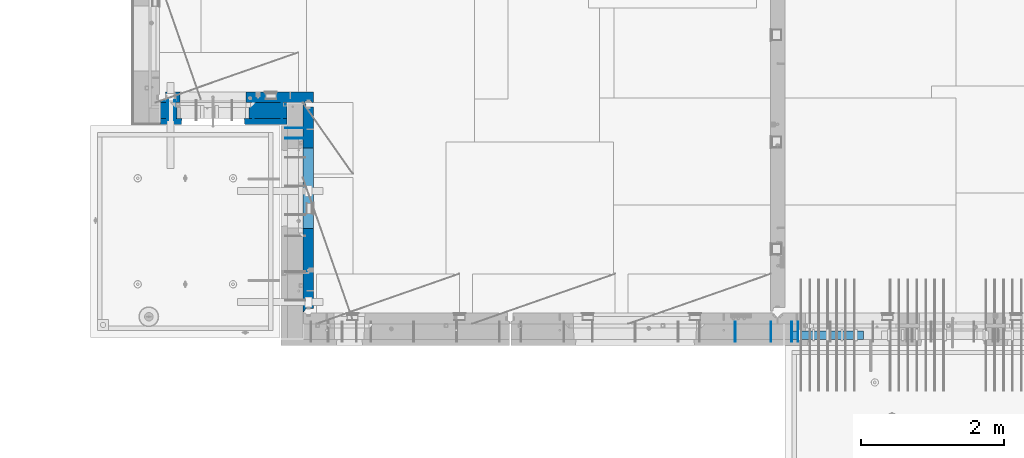
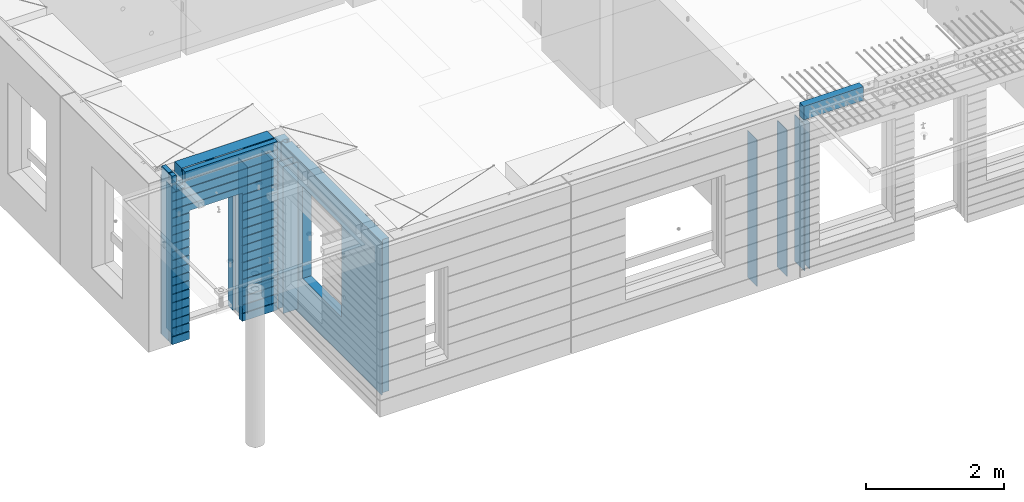
# One storey, part 220 of 341: 15 walls, 6 elements without a shape of their own.
"""IFC2X3 building model written with IfcOpenShell, lengths in millimetres."""

from ifc_helpers import new_model, si_unit, frame, origin_with_axes, place, context, subcontext, project, spatial, faceted_brep, material, type_object, element, aggregate, save


model = new_model("IFC2X3")

# Units and contexts
model_context = context("Model", 3, precision=1e-05, world=origin_with_axes())
body_context = subcontext(model_context, "Body", "Model", "MODEL_VIEW")
ifc_project = project(units=[si_unit("LENGTHUNIT", "METRE", prefix="MILLI"), si_unit("AREAUNIT", "SQUARE_METRE"), si_unit("VOLUMEUNIT", "CUBIC_METRE"), si_unit("MASSUNIT", "GRAM", prefix="KILO"), si_unit("TIMEUNIT", "SECOND"), si_unit("PLANEANGLEUNIT", "RADIAN"), si_unit("SOLIDANGLEUNIT", "STERADIAN"), si_unit("THERMODYNAMICTEMPERATUREUNIT", "DEGREE_CELSIUS"), si_unit("LUMINOUSINTENSITYUNIT", "LUMEN")], contexts=[model_context])

# Site, building, storey
site_placement = place(None, origin_with_axes())
site = spatial("IfcSite", under=ifc_project, at=site_placement, CompositionType="ELEMENT")
building_placement = place(site_placement, origin_with_axes())
building = spatial("IfcBuilding", under=site, at=building_placement, CompositionType="ELEMENT")
storey_placement = place(building_placement, origin_with_axes())
storey = spatial("IfcBuildingStorey", under=building, at=storey_placement, Name="5", CompositionType="ELEMENT", Elevation=0.0)

# Assembly, wall
assembly_1_placement = place(storey_placement, origin_with_axes())
assembly_1 = element("IfcElementAssembly", 1, at=assembly_1_placement, inside=storey, AssemblyPlace="NOTDEFINED", PredefinedType="REINFORCEMENT_UNIT")
ifc_material_1 = material(Name="Undefined")
wall_type_1 = type_object("IfcWallType", PredefinedType="NOTDEFINED")
wall_1_placement = place(assembly_1_placement, frame((16855.0, 7880.0, 95115.0), z_axis=(0.0, 0.0, 1.0), x_axis=(0.0, -1.0, 0.0)))
wall_1 = element("IfcWall", 2, at=wall_1_placement, type_object=wall_type_1, material=ifc_material_1, Name="(PD)", context=body_context, shape_type="Brep", body=[
    faceted_brep([(0.0, 5.0, -1300.0), (0.0, 5.0, 1300.0), (280.0, 5.0, 1300.0), (280.0, 5.0, -1300.0), (0.0, -5.0, 1300.0), (280.0, -5.0, 1300.0), (0.0, -5.0, -1300.0), (280.0, -5.0, -1300.0)], [[[0, 1, 2, 3]], [[1, 4, 5, 2]], [[4, 6, 7, 5]], [[6, 0, 3, 7]], [[5, 7, 3, 2]], [[6, 4, 1, 0]]]),
])

# Assembly, walls
assembly_2_placement = place(storey_placement, origin_with_axes())
assembly_2 = element("IfcElementAssembly", 3, at=assembly_2_placement, inside=storey, AssemblyPlace="NOTDEFINED", PredefinedType="REINFORCEMENT_UNIT")
wall_2_placement = place(assembly_2_placement, frame((16565.0, 7880.0, 95115.0), z_axis=(0.0, 0.0, 1.0), x_axis=(0.0, -1.0, 0.0)))
wall_2 = element("IfcWall", 4, at=wall_2_placement, type_object=wall_type_1, material=ifc_material_1, Name="(PD)", context=body_context, shape_type="Brep", body=[
    faceted_brep([(0.0, 5.0, -1300.0), (0.0, 5.0, 1300.0), (280.0, 5.0, 1300.0), (280.0, 5.0, -1300.0), (0.0, -5.0, 1300.0), (280.0, -5.0, 1300.0), (0.0, -5.0, -1300.0), (280.0, -5.0, -1300.0)], [[[0, 1, 2, 3]], [[1, 4, 5, 2]], [[4, 6, 7, 5]], [[6, 0, 3, 7]], [[5, 7, 3, 2]], [[6, 4, 1, 0]]]),
])
wall_3_placement = place(assembly_2_placement, frame((16065.0, 7880.0, 95115.0), z_axis=(0.0, 0.0, 1.0), x_axis=(0.0, -1.0, 0.0)))
wall_3 = element("IfcWall", 5, at=wall_3_placement, type_object=wall_type_1, material=ifc_material_1, Name="(PD)", context=body_context, shape_type="Brep", body=[
    faceted_brep([(0.0, 5.0, -1300.0), (0.0, 5.0, 1300.0), (280.0, 5.0, 1300.0), (280.0, 5.0, -1300.0), (0.0, -5.0, 1300.0), (280.0, -5.0, 1300.0), (0.0, -5.0, -1300.0), (280.0, -5.0, -1300.0)], [[[0, 1, 2, 3]], [[1, 4, 5, 2]], [[4, 6, 7, 5]], [[6, 0, 3, 7]], [[5, 7, 3, 2]], [[6, 4, 1, 0]]]),
])
aggregate(assembly_2, [wall_2, wall_3])

# Assembly, wall
assembly_3_placement = place(storey_placement, origin_with_axes())
assembly_3 = element("IfcElementAssembly", 6, at=assembly_3_placement, inside=storey, AssemblyPlace="NOTDEFINED", PredefinedType="REINFORCEMENT_UNIT")
wall_4_placement = place(assembly_3_placement, frame((8215.0, 10980.0, 95115.0), z_axis=(0.0, 0.0, 1.0), x_axis=(0.0, -1.0, 0.0)))
wall_4 = element("IfcWall", 7, at=wall_4_placement, type_object=wall_type_1, material=ifc_material_1, Name="(PD)", context=body_context, shape_type="Brep", body=[
    faceted_brep([(0.0, 5.0, -1300.0), (0.0, 5.0, 1300.0), (280.0, 5.0, 1300.0), (280.0, 5.0, -1300.0), (0.0, -5.0, 1300.0), (280.0, -5.0, 1300.0), (0.0, -5.0, -1300.0), (280.0, -5.0, -1300.0)], [[[0, 1, 2, 3]], [[1, 4, 5, 2]], [[4, 6, 7, 5]], [[6, 0, 3, 7]], [[5, 7, 3, 2]], [[6, 4, 1, 0]]]),
])

# Assembly, walls
assembly_4_placement = place(storey_placement, origin_with_axes())
assembly_4 = element("IfcElementAssembly", 8, at=assembly_4_placement, inside=storey, AssemblyPlace="NOTDEFINED", PredefinedType="REINFORCEMENT_UNIT")
wall_5_placement = place(assembly_4_placement, frame((10040.0, 10595.0, 95115.0), z_axis=(0.0, 0.0, 1.0), x_axis=(-1.0, 3.00000001838171e-08, 0.0)))
wall_5 = element("IfcWall", 9, at=wall_5_placement, type_object=wall_type_1, material=ifc_material_1, Name="(PD)", context=body_context, shape_type="Brep", body=[
    faceted_brep([(0.0, 5.0, -1300.0), (0.0, 5.0, 1300.0), (280.0, 5.0, 1300.0), (280.0, 5.0, -1300.0), (0.0, -5.0, 1300.0), (280.0, -5.0, 1300.0), (0.0, -5.0, -1300.0), (280.0, -5.0, -1300.0)], [[[0, 1, 2, 3]], [[1, 4, 5, 2]], [[4, 6, 7, 5]], [[6, 0, 3, 7]], [[5, 7, 3, 2]], [[6, 4, 1, 0]]]),
])
wall_6_placement = place(assembly_4_placement, frame((10040.0, 10450.0, 95115.0), z_axis=(0.0, 0.0, 1.0), x_axis=(-1.0, 3.00000001838171e-08, 0.0)))
wall_6 = element("IfcWall", 10, at=wall_6_placement, type_object=wall_type_1, material=ifc_material_1, Name="(PD)", context=body_context, shape_type="Brep", body=[
    faceted_brep([(0.0, 5.0, -1300.0), (0.0, 5.0, 1300.0), (280.0, 5.0, 1300.0), (280.0, 5.0, -1300.0), (0.0, -5.0, 1300.0), (280.0, -5.0, 1300.0), (0.0, -5.0, -1300.0), (280.0, -5.0, -1300.0)], [[[0, 1, 2, 3]], [[1, 4, 5, 2]], [[4, 6, 7, 5]], [[6, 0, 3, 7]], [[5, 7, 3, 2]], [[6, 4, 1, 0]]]),
])

# Wall
wall_7_placement = place(assembly_1_placement, frame((16945.0, 7880.0, 95115.0), z_axis=(0.0, 0.0, 1.0), x_axis=(0.0, -1.0, 0.0)))
wall_7 = element("IfcWall", 11, at=wall_7_placement, type_object=wall_type_1, material=ifc_material_1, Name="(PD)", context=body_context, shape_type="Brep", body=[
    faceted_brep([(0.0, 5.0, -1300.0), (0.0, 5.0, 1300.0), (280.0, 5.0, 1300.0), (280.0, 5.0, -1300.0), (0.0, -5.0, 1300.0), (280.0, -5.0, 1300.0), (0.0, -5.0, -1300.0), (280.0, -5.0, -1300.0)], [[[0, 1, 2, 3]], [[1, 4, 5, 2]], [[4, 6, 7, 5]], [[6, 0, 3, 7]], [[5, 7, 3, 2]], [[6, 4, 1, 0]]]),
])

aggregate(assembly_1, [wall_1, wall_7])

wall_8_placement = place(assembly_3_placement, frame((8115.0, 10980.0, 95115.0), z_axis=(0.0, 0.0, 1.0), x_axis=(0.0, -1.0, 0.0)))
wall_8 = element("IfcWall", 12, at=wall_8_placement, type_object=wall_type_1, material=ifc_material_1, Name="(PD)", context=body_context, shape_type="Brep", body=[
    faceted_brep([(0.0, 5.0, -1300.0), (0.0, 5.0, 1300.0), (280.0, 5.0, 1300.0), (280.0, 5.0, -1300.0), (0.0, -5.0, 1300.0), (280.0, -5.0, 1300.0), (0.0, -5.0, -1300.0), (280.0, -5.0, -1300.0)], [[[0, 1, 2, 3]], [[1, 4, 5, 2]], [[4, 6, 7, 5]], [[6, 0, 3, 7]], [[5, 7, 3, 2]], [[6, 4, 1, 0]]]),
])

wall_9_placement = place(assembly_3_placement, frame((9315.0, 10980.0, 95115.0), z_axis=(0.0, 0.0, 1.0), x_axis=(0.0, -1.0, 0.0)))
wall_9 = element("IfcWall", 13, at=wall_9_placement, type_object=wall_type_1, material=ifc_material_1, Name="(PD)", context=body_context, shape_type="Brep", body=[
    faceted_brep([(0.0, 5.0, -1300.0), (0.0, 5.0, 1300.0), (280.0, 5.0, 1300.0), (280.0, 5.0, -1300.0), (0.0, -5.0, 1300.0), (280.0, -5.0, 1300.0), (0.0, -5.0, -1300.0), (280.0, -5.0, -1300.0)], [[[0, 1, 2, 3]], [[1, 4, 5, 2]], [[4, 6, 7, 5]], [[6, 0, 3, 7]], [[5, 7, 3, 2]], [[6, 4, 1, 0]]]),
])

wall_10_placement = place(assembly_3_placement, frame((9715.0, 10980.0, 95115.0), z_axis=(0.0, 0.0, 1.0), x_axis=(0.0, -1.0, 0.0)))
wall_10 = element("IfcWall", 14, at=wall_10_placement, type_object=wall_type_1, material=ifc_material_1, Name="(PD)", context=body_context, shape_type="Brep", body=[
    faceted_brep([(0.0, 5.0, -1300.0), (0.0, 5.0, 1300.0), (280.0, 5.0, 1300.0), (280.0, 5.0, -1300.0), (0.0, -5.0, 1300.0), (280.0, -5.0, 1300.0), (0.0, -5.0, -1300.0), (280.0, -5.0, -1300.0)], [[[0, 1, 2, 3]], [[1, 4, 5, 2]], [[4, 6, 7, 5]], [[6, 0, 3, 7]], [[5, 7, 3, 2]], [[6, 4, 1, 0]]]),
])

# Assemblies, wall
assembly_5_placement = place(storey_placement, origin_with_axes())
assembly_5 = element("IfcElementAssembly", 15, at=assembly_5_placement, inside=storey, AssemblyPlace="NOTDEFINED", PredefinedType="REINFORCEMENT_UNIT")
assembly_6_placement = place(assembly_5_placement, origin_with_axes())
assembly_6 = element("IfcElementAssembly", 16, at=assembly_6_placement, Name="Steel Assembly", AssemblyPlace="NOTDEFINED", PredefinedType="NOTDEFINED")
aggregate(assembly_5, [assembly_6])
ifc_material_2 = material()
wall_type_2 = type_object("IfcWallType", PredefinedType="NOTDEFINED")
wall_11_placement = place(assembly_6_placement, frame((16859.9998568133, 7690.00021946163, 96590.0), z_axis=(0.0, 0.0, 1.0), x_axis=(1.0, 0.0, 0.0)))
wall_11 = element("IfcWall", 17, at=wall_11_placement, type_object=wall_type_2, material=ifc_material_2, context=body_context, shape_type="Brep", body=[
    faceted_brep([(0.0, 60.0, -120.0), (0.0, 60.0, 120.0), (1000.0, 60.0, 120.0), (1000.0, 60.0, -120.0), (0.0, -60.0, 120.0), (1000.0, -60.0, 120.0), (0.0, -60.0, -120.0), (1000.0, -60.0, -120.0)], [[[0, 1, 2, 3]], [[1, 4, 5, 2]], [[4, 6, 7, 5]], [[6, 0, 3, 7]], [[5, 7, 3, 2]], [[6, 4, 1, 0]]]),
])
aggregate(assembly_6, [wall_11])

# Wall
ifc_material_3 = material(Name="COS5gt")
wall_type_3 = type_object("IfcWallType", PredefinedType="NOTDEFINED")
wall_12_placement = place(assembly_3_placement, frame((9784.0, 10840.0, 95247.5), z_axis=(0.0, 0.0, 1.0), x_axis=(-1.0, 3.00000001838171e-08, 0.0)))
wall_12 = element("IfcWall", 18, at=wall_12_placement, type_object=wall_type_3, material=ifc_material_3, context=body_context, shape_type="Brep", body=[
    faceted_brep([(1699.0, -110.0, 1492.5), (1699.0, 90.0, 1492.5), (1699.0, 90.0, 1442.5), (1699.0, 110.0, 1442.5), (1699.0, 110.0, 1222.5), (1699.0, -110.0, 1222.5), (1549.0, 110.0, 1222.5), (1549.0, -110.0, 1222.5), (1549.0, -110.0, 1492.5), (1549.0, 110.0, 1442.5), (1549.0, 90.0, 1442.5), (1549.0, 90.0, 1492.5), (0.0, -110.0, -1492.5), (0.0, 90.0, -1492.5), (529.001442432404, 90.0, -1492.5), (529.001442432404, -110.0, -1492.5), (0.0, 90.0, -1442.5), (0.0, 110.0, -1442.5), (529.001442432404, 110.0, -1442.5), (529.001442432404, 90.0, -1442.5), (1769.0, 90.0, -1442.5), (1769.0, 90.0, -1492.5), (1539.0014424324, 90.0, -1492.5), (1539.0014424324, 90.0, -1442.5), (1769.0, 110.0, -1442.5), (1539.0014424324, 110.0, -1442.5), (1769.0, 110.0, 1442.5), (1769.0, 90.0, 1442.5), (1769.0, 90.0, 1492.5), (1769.0, -110.0, 1492.5), (1769.0, -110.0, -1492.5), (1539.0014424324, -110.0, -1492.5), (1539.0014424324, -110.0, 847.5), (1539.0014424324, 110.0, 847.5), (529.001442432404, -110.0, 847.5), (529.001442432404, 110.0, 847.5), (0.0, -110.0, 1492.5), (0.0, 90.0, 1492.5), (0.0, 90.0, 1442.5), (0.0, 110.0, 1442.5)], [[[0, 1, 2, 3, 4, 5]], [[5, 4, 6, 7]], [[8, 7, 6, 9, 10, 11]], [[12, 13, 14, 15]], [[16, 17, 18, 19]], [[20, 21, 22, 23]], [[24, 20, 23, 25]], [[26, 27, 28, 29, 30, 21, 20, 24]], [[21, 30, 31, 22]], [[32, 33, 25, 23, 22, 31]], [[34, 35, 33, 32]], [[15, 14, 19, 18, 35, 34]], [[13, 16, 19, 14]], [[13, 12, 36, 37, 38, 39, 17, 16]], [[37, 36, 8, 11]], [[38, 37, 11, 10]], [[39, 38, 10, 9]], [[4, 3, 26, 24, 25, 33, 35, 18, 17, 39, 9, 6]], [[27, 26, 3, 2]], [[28, 27, 2, 1]], [[29, 28, 1, 0]], [[36, 12, 15, 34, 32, 31, 30, 29, 0, 5, 7, 8]]]),
])

ifc_material_4 = material(Name="CONCRETE/C30/37")
wall_type_4 = type_object("IfcWallType", PredefinedType="NOTDEFINED")
wall_13_placement = place(assembly_3_placement, frame((9784.0, 10687.5, 95247.5), z_axis=(0.0, 0.0, 1.0), x_axis=(-1.0, 3.00000001838171e-08, 0.0)))
wall_13 = element("IfcWall", 19, at=wall_13_placement, type_object=wall_type_4, material=ifc_material_4, context=body_context, shape_type="Brep", body=[
    faceted_brep([(1699.0, -42.5, 1492.5), (1699.0, 42.5, 1492.5), (1699.0, 42.5, 1356.99999988925), (1699.0, 32.4999991126988, 1355.00000040044), (1699.0, 32.4999992506928, 1344.99999999921), (1699.0, 42.5, 1342.99999994476), (1699.0, 42.5, 1222.5), (1699.0, -42.5, 1222.5), (1549.0, 42.5, 1222.5), (1549.0, -42.5, 1222.5), (1549.0, -42.5, 1492.5), (1549.0, 42.5, 1342.99999994476), (1549.0, 32.4999992506928, 1344.99999999921), (1549.0, 32.4999991126988, 1355.00000040044), (1549.0, 42.5, 1356.99999988925), (1549.0, 42.5, 1492.5), (1478.99938360887, 42.5, 606.999999889245), (1769.0, 42.5, 606.999999889245), (1769.0, 32.4999991126988, 605.00000040044), (1477.8227168378, 32.4999991126988, 605.00000040044), (1769.0, 32.4999992506928, 594.999999999214), (1477.82271685404, 32.4999992506928, 594.999999999214), (1769.0, 42.5, 592.999999944761), (1478.99938360887, 42.5, 592.999999944761), (1769.0, 42.5, 456.999999889245), (1478.99938360887, 42.5, 456.999999889245), (1769.0, 32.4999991126988, 455.00000040044), (1477.8227168378, 32.4999991126988, 455.00000040044), (1769.0, 32.4999992506928, 444.999999999214), (1477.82271685404, 32.4999992506928, 444.999999999214), (1769.0, 42.5, 442.999999944761), (1478.99938360887, 42.5, 442.999999944761), (1769.0, 42.5, 306.999999889245), (1478.99938360887, 42.5, 306.999999889245), (1769.0, 32.4999991126988, 305.00000040044), (1477.8227168378, 32.4999991126988, 305.00000040044), (1769.0, 32.4999992506928, 294.999999999214), (1477.82271685404, 32.4999992506928, 294.999999999214), (1769.0, 42.5, 292.999999944761), (1478.99938360887, 42.5, 292.999999944761), (1769.0, 42.5, 156.999999889245), (1478.99938360887, 42.5, 156.999999889245), (1769.0, 32.4999991126988, 155.00000040044), (1477.8227168378, 32.4999991126988, 155.00000040044), (1769.0, 32.4999992506928, 144.999999999214), (1477.82271685404, 32.4999992506928, 144.999999999214), (1769.0, 42.5, 142.999999944761), (1478.99938360887, 42.5, 142.999999944761), (1769.0, 42.5, 6.99999988924537), (1478.99938360887, 42.5, 6.99999988924537), (1769.0, 32.4999991126988, 5.0000004004396), (1477.8227168378, 32.4999991126988, 5.0000004004396), (1769.0, 32.4999992506928, -5.0000000007858), (1477.82271685404, 32.4999992506928, -5.0000000007858), (1769.0, 42.5, -7.00000005523907), (1478.99938360887, 42.5, -7.00000005523907), (1769.0, 42.5, -143.000000110755), (1478.99938360887, 42.5, -143.000000110755), (1769.0, 32.4999991126988, -144.99999959956), (1477.8227168378, 32.4999991126988, -144.99999959956), (1769.0, 32.4999992506928, -155.000000000786), (1477.82271685404, 32.4999992506928, -155.000000000786), (1769.0, 42.5, -157.000000055239), (1478.99938360887, 42.5, -157.000000055239), (1769.0, 42.5, -293.000000110755), (1478.99938360887, 42.5, -293.000000110755), (1769.0, 32.4999991126988, -294.99999959956), (1477.8227168378, 32.4999991126988, -294.99999959956), (1769.0, 32.4999992506928, -305.000000000786), (1477.82271685404, 32.4999992506928, -305.000000000786), (1769.0, 42.5, -307.000000055239), (1478.99938360887, 42.5, -307.000000055239), (1769.0, 42.5, -443.000000110755), (1478.99938360887, 42.5, -443.000000110755), (1769.0, 32.4999991126988, -444.99999959956), (1477.8227168378, 32.4999991126988, -444.99999959956), (1769.0, 32.4999992506928, -455.000000000786), (1477.82271685404, 32.4999992506928, -455.000000000786), (1769.0, 42.5, -457.000000055239), (1478.99938360887, 42.5, -457.000000055239), (1769.0, 42.5, -593.000000110755), (1478.99938360887, 42.5, -593.000000110755), (1769.0, 32.4999991126988, -594.99999959956), (1477.8227168378, 32.4999991126988, -594.99999959956), (1769.0, 32.4999992506928, -605.000000000786), (1477.82271685404, 32.4999992506928, -605.000000000786), (1769.0, 42.5, -607.000000055239), (1478.99938360887, 42.5, -607.000000055239), (1769.0, 42.5, -743.000000110755), (1478.99938360887, 42.5, -743.000000110755), (1769.0, 32.4999991126988, -744.99999959956), (1477.8227168378, 32.4999991126988, -744.99999959956), (1769.0, 32.4999992506928, -755.000000000786), (1477.82271685404, 32.4999992506928, -755.000000000786), (1769.0, 42.5, -757.000000055239), (1478.99938360887, 42.5, -757.000000055239), (1769.0, 42.5, -893.000000110755), (1478.99938360887, 42.5, -893.000000110755), (1769.0, 32.4999991126988, -894.99999959956), (1477.8227168378, 32.4999991126988, -894.99999959956), (1769.0, 32.4999992506928, -905.000000000786), (1477.82271685404, 32.4999992506928, -905.000000000786), (1769.0, 42.5, -907.000000055239), (1478.99938360887, 42.5, -907.000000055239), (1769.0, 42.5, -1043.00000011075), (1478.99938360887, 42.5, -1043.00000011075), (1769.0, 32.4999991126988, -1044.99999959956), (1477.8227168378, 32.4999991126988, -1044.99999959956), (1769.0, 32.4999992506928, -1055.00000000079), (1477.82271685404, 32.4999992506928, -1055.00000000079), (1769.0, 42.5, -1057.00000005524), (1478.99938360887, 42.5, -1057.00000005524), (1769.0, 42.5, -1193.00000011075), (1478.99938360887, 42.5, -1193.00000011075), (1769.0, 32.4999991126988, -1194.99999959956), (1477.8227168378, 32.4999991126988, -1194.99999959956), (1769.0, 32.4999992506928, -1205.00000000079), (1477.82271685404, 32.4999992506928, -1205.00000000079), (1769.0, 42.5, -1207.00000005524), (1478.99938360887, 42.5, -1207.00000005524), (1769.0, 42.5, -1343.00000011075), (1478.99938360887, 42.5, -1343.00000011075), (1769.0, 32.4999991126988, -1344.99999959956), (1477.8227168378, 32.4999991126988, -1344.99999959956), (1769.0, 32.4999992506928, -1355.00000000079), (1477.82271685404, 32.4999992506928, -1355.00000000079), (1769.0, 42.5, -1357.00000005524), (1478.99938360887, 42.5, -1357.00000005524), (1769.0, 42.5, -1492.5), (1478.99938360887, 42.5, -1492.5), (1769.0, -42.5, -1492.5), (1468.99771694221, -42.5, -1492.5), (599.001442432404, 42.5, 782.5), (1469.0014424324, 42.5, 782.5), (1478.99938360887, 42.5, 782.5), (1468.99771694221, -42.5, 787.502857142856), (599.001050275541, -42.5, 787.502857142856), (588.999383608874, 42.5, 782.5), (1478.99938360887, 42.5, 742.999999944761), (1468.99771694221, -42.5, 782.5), (1478.99938360887, 42.5, 756.999999889245), (1477.82271683781, 32.4999991126988, 755.00000040044), (1477.82271685404, 32.4999992506928, 744.999999999214), (1769.0, 42.5, 742.999999944761), (1769.0, 32.4999992506928, 744.999999999214), (1769.0, 32.4999991126988, 755.00000040044), (1769.0, 42.5, 756.999999889245), (0.0, 32.4999991127006, 905.00000040044), (1769.0, 32.4999991126988, 905.00000040044), (1769.0, 32.4999992506928, 894.999999999214), (0.0, 32.4999992507037, 894.999999999258), (0.0, 42.5, 906.999999889245), (1769.0, 42.5, 906.999999889245), (0.0, 42.5, 1042.99999994476), (1769.0, 42.5, 1042.99999994476), (0.0, 32.4999992507037, 1044.99999999926), (1769.0, 32.4999992506928, 1044.99999999921), (0.0, 32.4999991127006, 1055.00000040044), (1769.0, 32.4999991126988, 1055.00000040044), (0.0, 42.5, 1056.99999988925), (1769.0, 42.5, 1056.99999988925), (0.0, 42.5, 1192.99999994476), (1769.0, 42.5, 1192.99999994476), (0.0, 32.4999992507037, 1194.99999999926), (1769.0, 32.4999992506928, 1194.99999999921), (0.0, 32.4999991127006, 1205.00000040044), (1769.0, 32.4999991126988, 1205.00000040044), (0.0, 42.5, 1206.99999988925), (1769.0, 42.5, 1206.99999988925), (1769.0, 42.5, 1492.5), (1769.0, -42.5, 1492.5), (1769.0, 42.5, 892.999999944761), (1769.0, 42.5, 1342.99999994476), (1769.0, 32.4999992506928, 1344.99999999921), (1769.0, 32.4999991126988, 1355.00000040044), (1769.0, 42.5, 1356.99999988925), (0.0, 42.5, 892.999999944761), (588.999383608874, 42.5, 756.999999889245), (0.0, 42.5, 756.999999889245), (588.999383608874, 42.5, -1492.5), (0.0, 42.5, -1492.5), (0.0, 42.5, -1357.00000005524), (588.999383608874, 42.5, -1357.00000005524), (0.0, 32.4999992507037, -1355.00000000074), (590.176050363707, 32.4999992506928, -1355.00000000079), (0.0, 32.4999991127006, -1344.99999959956), (590.176050379945, 32.4999991126988, -1344.99999959956), (0.0, 42.5, -1343.00000011075), (588.999383608874, 42.5, -1343.00000011075), (0.0, 42.5, -1207.00000005524), (588.999383608874, 42.5, -1207.00000005524), (0.0, 32.4999992507037, -1205.00000000074), (590.176050363709, 32.4999992506928, -1205.00000000079), (0.0, 32.4999991127006, -1194.99999959956), (590.176050379947, 32.4999991126988, -1194.99999959956), (0.0, 42.5, -1193.00000011075), (588.999383608874, 42.5, -1193.00000011075), (0.0, 42.5, -1057.00000005524), (588.999383608874, 42.5, -1057.00000005524), (0.0, 32.4999992507037, -1055.00000000074), (590.176050363711, 32.4999992506928, -1055.00000000079), (0.0, 32.4999991127006, -1044.99999959956), (590.176050379947, 32.4999991126988, -1044.99999959956), (0.0, 42.5, -1043.00000011075), (588.999383608874, 42.5, -1043.00000011075), (0.0, 42.5, -907.000000055239), (588.999383608874, 42.5, -907.000000055239), (0.0, 32.4999992507037, -905.000000000742), (590.176050363711, 32.4999992506928, -905.000000000786), (0.0, 32.4999991127006, -894.99999959956), (590.176050379947, 32.4999991126988, -894.99999959956), (0.0, 42.5, -893.000000110755), (588.999383608874, 42.5, -893.000000110755), (0.0, 42.5, -757.000000055239), (588.999383608874, 42.5, -757.000000055239), (0.0, 32.4999992507037, -755.000000000742), (590.176050363711, 32.4999992506928, -755.000000000786), (0.0, 32.4999991127006, -744.99999959956), (590.176050379947, 32.4999991126988, -744.99999959956), (0.0, 42.5, -743.000000110755), (588.999383608874, 42.5, -743.000000110755), (0.0, 42.5, -607.000000055239), (588.999383608874, 42.5, -607.000000055239), (3.63797880709171e-12, 32.4999992507037, -605.000000000742), (590.176050363709, 32.4999992506928, -605.000000000786), (3.63797880709171e-12, 32.4999991127006, -594.99999959956), (590.176050379947, 32.4999991126988, -594.99999959956), (0.0, 42.5, -593.000000110755), (588.999383608874, 42.5, -593.000000110755), (0.0, 42.5, -457.000000055239), (588.999383608874, 42.5, -457.000000055239), (0.0, 32.4999992507037, -455.000000000742), (590.176050363711, 32.4999992506928, -455.000000000786), (0.0, 32.4999991127006, -444.99999959956), (590.176050379947, 32.4999991126988, -444.99999959956), (0.0, 42.5, -443.000000110755), (588.999383608874, 42.5, -443.000000110755), (0.0, 42.5, -307.000000055239), (588.999383608874, 42.5, -307.000000055239), (0.0, 32.4999992507037, -305.000000000742), (590.176050363711, 32.4999992506928, -305.000000000786), (0.0, 32.4999991127006, -294.99999959956), (590.176050379947, 32.4999991126988, -294.99999959956), (0.0, 42.5, -293.000000110755), (588.999383608874, 42.5, -293.000000110755), (0.0, 42.5, -157.000000055239), (588.999383608874, 42.5, -157.000000055239), (3.63797880709171e-12, 32.4999992507037, -155.000000000742), (590.176050363707, 32.4999992506928, -155.000000000786), (3.63797880709171e-12, 32.4999991127006, -144.99999959956), (590.176050379945, 32.4999991126988, -144.99999959956), (0.0, 42.5, -143.000000110755), (588.999383608874, 42.5, -143.000000110755), (0.0, 42.5, -7.00000005523907), (588.999383608874, 42.5, -7.00000005523907), (0.0, 32.4999992507037, -5.00000000074215), (590.176050363705, 32.4999992506928, -5.0000000007858), (0.0, 32.4999991127006, 5.0000004004396), (590.176050379941, 32.4999991126988, 5.0000004004396), (0.0, 42.5, 6.99999988924537), (588.999383608874, 42.5, 6.99999988924537), (0.0, 42.5, 142.999999944761), (588.999383608874, 42.5, 142.999999944761), (-3.63797880709171e-12, 32.4999992507037, 144.999999999258), (590.176050363705, 32.4999992506928, 144.999999999214), (-3.63797880709171e-12, 32.4999991127006, 155.00000040044), (590.176050379943, 32.4999991126988, 155.00000040044), (0.0, 42.5, 156.999999889245), (588.999383608874, 42.5, 156.999999889245), (0.0, 42.5, 292.999999944761), (588.999383608874, 42.5, 292.999999944761), (-3.63797880709171e-12, 32.4999992507037, 294.999999999258), (590.176050363703, 32.4999992506928, 294.999999999214), (-3.63797880709171e-12, 32.4999991127006, 305.00000040044), (590.17605037994, 32.4999991126988, 305.00000040044), (0.0, 42.5, 306.999999889245), (588.999383608874, 42.5, 306.999999889245), (0.0, 42.5, 442.999999944761), (588.999383608874, 42.5, 442.999999944761), (0.0, 32.4999992507037, 444.999999999258), (590.176050363702, 32.4999992506928, 444.999999999214), (0.0, 32.4999991127006, 455.00000040044), (590.176050379938, 32.4999991126988, 455.00000040044), (0.0, 42.5, 456.999999889245), (588.999383608874, 42.5, 456.999999889245), (0.0, 42.5, 592.999999944761), (588.999383608874, 42.5, 592.999999944761), (3.63797880709171e-12, 32.4999992507037, 594.999999999258), (590.176050363702, 32.4999992506928, 594.999999999214), (3.63797880709171e-12, 32.4999991127006, 605.00000040044), (590.17605037994, 32.4999991126988, 605.00000040044), (0.0, 42.5, 606.999999889245), (588.999383608874, 42.5, 606.999999889245), (0.0, 42.5, 742.999999944761), (588.999383608874, 42.5, 742.999999944761), (0.0, 32.4999992507037, 744.999999999258), (590.176050363705, 32.4999992506928, 744.999999999214), (0.0, 32.4999991127006, 755.00000040044), (590.176050379943, 32.4999991126988, 755.00000040044), (599.001050275541, -42.5, 782.5), (599.001050275539, -42.5, -1492.5), (0.0, -42.5, -1492.5), (-3.63797880709171e-12, 32.4999992507037, 1344.99999999926), (0.0, 42.5, 1342.99999994476), (0.0, -42.5, 1492.5), (0.0, 42.5, 1492.5), (0.0, 42.5, 1356.99999988925), (-3.63797880709171e-12, 32.4999991127006, 1355.00000040044)], [[[0, 1, 2, 3, 4, 5, 6, 7]], [[7, 6, 8, 9]], [[10, 9, 8, 11, 12, 13, 14, 15]], [[16, 17, 18, 19]], [[19, 18, 20, 21]], [[21, 20, 22, 23]], [[24, 25, 23, 22]], [[25, 24, 26, 27]], [[27, 26, 28, 29]], [[29, 28, 30, 31]], [[32, 33, 31, 30]], [[33, 32, 34, 35]], [[35, 34, 36, 37]], [[37, 36, 38, 39]], [[40, 41, 39, 38]], [[41, 40, 42, 43]], [[43, 42, 44, 45]], [[45, 44, 46, 47]], [[48, 49, 47, 46]], [[49, 48, 50, 51]], [[51, 50, 52, 53]], [[53, 52, 54, 55]], [[56, 57, 55, 54]], [[57, 56, 58, 59]], [[59, 58, 60, 61]], [[61, 60, 62, 63]], [[64, 65, 63, 62]], [[65, 64, 66, 67]], [[67, 66, 68, 69]], [[69, 68, 70, 71]], [[72, 73, 71, 70]], [[73, 72, 74, 75]], [[75, 74, 76, 77]], [[77, 76, 78, 79]], [[80, 81, 79, 78]], [[81, 80, 82, 83]], [[83, 82, 84, 85]], [[85, 84, 86, 87]], [[88, 89, 87, 86]], [[89, 88, 90, 91]], [[91, 90, 92, 93]], [[93, 92, 94, 95]], [[96, 97, 95, 94]], [[97, 96, 98, 99]], [[99, 98, 100, 101]], [[101, 100, 102, 103]], [[104, 105, 103, 102]], [[105, 104, 106, 107]], [[107, 106, 108, 109]], [[109, 108, 110, 111]], [[112, 113, 111, 110]], [[113, 112, 114, 115]], [[115, 114, 116, 117]], [[117, 116, 118, 119]], [[120, 121, 119, 118]], [[121, 120, 122, 123]], [[123, 122, 124, 125]], [[125, 124, 126, 127]], [[128, 129, 127, 126]], [[128, 130, 131, 129]], [[132, 133, 134, 135, 136, 137]], [[138, 16, 19, 21, 23, 25, 27, 29, 31, 33, 35, 37, 39, 41, 43, 45, 47, 49, 51, 53, 55, 57, 59, 61, 63, 65, 67, 69, 71, 73, 75, 77, 79, 81, 83, 85, 87, 89, 91, 93, 95, 97, 99, 101, 103, 105, 107, 109, 111, 113, 115, 117, 119, 121, 123, 125, 127, 129, 131, 139, 135, 134, 140, 141, 142]], [[17, 16, 138, 143]], [[142, 144, 143, 138]], [[141, 145, 144, 142]], [[140, 146, 145, 141]], [[147, 148, 149, 150]], [[151, 152, 148, 147]], [[152, 151, 153, 154]], [[155, 156, 154, 153]], [[157, 158, 156, 155]], [[159, 160, 158, 157]], [[160, 159, 161, 162]], [[163, 164, 162, 161]], [[165, 166, 164, 163]], [[167, 168, 166, 165]], [[169, 170, 130, 128, 126, 124, 122, 120, 118, 116, 114, 112, 110, 108, 106, 104, 102, 100, 98, 96, 94, 92, 90, 88, 86, 84, 82, 80, 78, 76, 74, 72, 70, 68, 66, 64, 62, 60, 58, 56, 54, 52, 50, 48, 46, 44, 42, 40, 38, 36, 34, 32, 30, 28, 26, 24, 22, 20, 18, 17, 143, 144, 145, 146, 171, 149, 148, 152, 154, 156, 158, 160, 162, 164, 166, 168, 172, 173, 174, 175]], [[150, 149, 171, 176]], [[146, 140, 134, 133, 132, 137, 177, 178, 176, 171]], [[179, 180, 181, 182]], [[183, 184, 182, 181]], [[185, 186, 184, 183]], [[187, 188, 186, 185]], [[188, 187, 189, 190]], [[191, 192, 190, 189]], [[193, 194, 192, 191]], [[195, 196, 194, 193]], [[196, 195, 197, 198]], [[199, 200, 198, 197]], [[201, 202, 200, 199]], [[203, 204, 202, 201]], [[204, 203, 205, 206]], [[207, 208, 206, 205]], [[209, 210, 208, 207]], [[211, 212, 210, 209]], [[212, 211, 213, 214]], [[215, 216, 214, 213]], [[217, 218, 216, 215]], [[219, 220, 218, 217]], [[220, 219, 221, 222]], [[223, 224, 222, 221]], [[225, 226, 224, 223]], [[227, 228, 226, 225]], [[228, 227, 229, 230]], [[231, 232, 230, 229]], [[233, 234, 232, 231]], [[235, 236, 234, 233]], [[236, 235, 237, 238]], [[239, 240, 238, 237]], [[241, 242, 240, 239]], [[243, 244, 242, 241]], [[244, 243, 245, 246]], [[247, 248, 246, 245]], [[249, 250, 248, 247]], [[251, 252, 250, 249]], [[252, 251, 253, 254]], [[255, 256, 254, 253]], [[257, 258, 256, 255]], [[259, 260, 258, 257]], [[260, 259, 261, 262]], [[263, 264, 262, 261]], [[265, 266, 264, 263]], [[267, 268, 266, 265]], [[268, 267, 269, 270]], [[271, 272, 270, 269]], [[273, 274, 272, 271]], [[275, 276, 274, 273]], [[276, 275, 277, 278]], [[279, 280, 278, 277]], [[281, 282, 280, 279]], [[283, 284, 282, 281]], [[284, 283, 285, 286]], [[287, 288, 286, 285]], [[289, 290, 288, 287]], [[291, 292, 290, 289]], [[292, 291, 293, 294]], [[295, 296, 294, 293]], [[297, 298, 296, 295]], [[178, 177, 298, 297]], [[137, 136, 299, 300, 179, 182, 184, 186, 188, 190, 192, 194, 196, 198, 200, 202, 204, 206, 208, 210, 212, 214, 216, 218, 220, 222, 224, 226, 228, 230, 232, 234, 236, 238, 240, 242, 244, 246, 248, 250, 252, 254, 256, 258, 260, 262, 264, 266, 268, 270, 272, 274, 276, 278, 280, 282, 284, 286, 288, 290, 292, 294, 296, 298, 177]], [[301, 180, 179, 300]], [[302, 303, 167, 165, 163, 161, 159, 157, 155, 153, 151, 147, 150, 176, 178, 297, 295, 293, 291, 289, 287, 285, 283, 281, 279, 277, 275, 273, 271, 269, 267, 265, 263, 261, 259, 257, 255, 253, 251, 249, 247, 245, 243, 241, 239, 237, 235, 233, 231, 229, 227, 225, 223, 221, 219, 217, 215, 213, 211, 209, 207, 205, 203, 201, 199, 197, 195, 193, 191, 189, 187, 185, 183, 181, 180, 301, 304, 305, 306, 307]], [[305, 304, 10, 15]], [[306, 305, 15, 14]], [[307, 306, 14, 13]], [[302, 307, 13, 12]], [[303, 302, 12, 11]], [[6, 5, 172, 168, 167, 303, 11, 8]], [[173, 172, 5, 4]], [[174, 173, 4, 3]], [[175, 174, 3, 2]], [[169, 175, 2, 1]], [[170, 169, 1, 0]], [[304, 301, 300, 299, 136, 135, 139, 131, 130, 170, 0, 7, 9, 10]]]),
])

ifc_material_5 = material(Name="CONCRETE/C25/30")
wall_type_5 = type_object("IfcWallType", PredefinedType="NOTDEFINED")
wall_14_placement = place(assembly_4_placement, frame((10085.0, 8000.0, 95112.5), z_axis=(0.0, 0.0, 1.0), x_axis=(0.0, 1.0, 0.0)))
wall_14 = element("IfcWall", 20, at=wall_14_placement, type_object=wall_type_5, material=ifc_material_5, context=body_context, shape_type="Brep", body=[
    faceted_brep([(2885.0, -75.0, 1357.5), (2885.0, -75.0, -1357.5), (2885.0, 27.0, -1357.5), (2885.0, 27.0, 1357.5), (2934.99999772087, 40.0, 1357.5), (2934.99999772087, 75.0, 1357.5), (15.0, 75.0, 1357.5), (15.0, 65.0, 1357.5), (65.0, 35.0, 1357.5), (65.0, -75.0, 1357.5), (15.0, 75.0, -1357.5), (15.0, 65.0, -1357.5), (65.0, 35.0, -1357.5), (65.0, -75.0, -1357.5), (1380.0, -75.0, -1357.5), (1380.0, -74.9999999938009, -1207.49999999684), (1550.0, -74.9999999938009, -1207.49999999684), (1550.0, -75.0, -1357.5), (1185.00311728789, -75.0000000030959, -682.5), (1185.00311728789, -75.0000000030959, 952.5), (2315.00311728789, -75.0000000030959, 952.5), (2315.00311728789, -75.0000000030959, -682.5), (1380.0, -72.9999999938009, -1207.49999999684), (1550.0, -72.9999999938009, -1207.49999999684), (1380.0, -72.9999999938009, -1357.4999999999), (1550.0, -72.9999999938009, -1357.4999999999), (2934.99999772087, 75.0, -1357.5), (2934.99999772087, 40.0, -1357.5), (1189.05717134203, 75.0, -678.445945945859), (2310.94906323375, 75.0, -678.445945945859), (2310.94906323375, 75.0, 948.445945945859), (1189.05717134203, 75.0, 948.445945945859)], [[[0, 1, 2, 3]], [[4, 5, 6, 7, 8, 9, 0, 3]], [[6, 10, 11, 7]], [[7, 11, 12, 8]], [[9, 8, 12, 13]], [[1, 0, 9, 13, 14, 15, 16, 17], [18, 19, 20, 21]], [[15, 22, 23, 16]], [[14, 24, 22, 15]], [[25, 23, 22, 24]], [[16, 23, 25, 17]], [[24, 14, 13, 12, 11, 10, 26, 27, 2, 1, 17, 25]], [[3, 2, 27, 4]], [[26, 5, 4, 27]], [[10, 6, 5, 26], [28, 29, 30, 31]], [[20, 30, 29, 21]], [[19, 31, 30, 20]], [[18, 28, 31, 19]], [[21, 29, 28, 18]]]),
])

aggregate(assembly_4, [wall_5, wall_6, wall_14])

wall_15_placement = place(assembly_3_placement, frame((10160.0, 11025.0, 95112.5), z_axis=(0.0, 0.0, 1.0), x_axis=(-1.0, 3.00000001838171e-08, 0.0)))
wall_15 = element("IfcWall", 21, at=wall_15_placement, type_object=wall_type_5, material=ifc_material_5, context=body_context, shape_type="Brep", body=[
    faceted_brep([(47.9999996848892, 54.9999994175323, 1357.5), (47.9999996848892, 54.9999994175323, -1357.5), (34.999999998452, 55.0000022791301, -1357.5), (34.999999998452, 55.0000022791301, 1357.5), (24.999999998452, 75.0000022791301, 1357.5), (24.999999998452, 75.0, -1357.5), (124.999999998452, 75.0, 1357.5), (124.999999998452, 75.0, -1357.5), (114.999999998452, 55.0000022791301, -1357.5), (114.999999998452, 55.0000022791301, 1357.5), (101.99999958942, 54.999999390373, 1357.5), (101.99999958942, 54.999999390373, -1357.5), (945.001442432404, -75.0, -1357.5), (949.055496486459, 75.0, -1357.5), (949.055496486457, 75.0, 948.445945945947), (945.001442432404, -75.0, 952.5), (0.0, -75.0, -1357.5), (0.0, 75.0, -1357.5), (2145.0, 75.0, 1357.5), (2145.0, 75.0, -1357.5), (1870.94738837835, 75.0, -1357.5), (1870.94738837835, 75.0, 948.445945945947), (2145.0, 45.0, 1357.5), (2145.0, 45.0, -1357.5), (2074.9999995581, 32.0, 1357.5), (2074.9999995581, 32.0, -1357.5), (2074.9999995581, -75.0, 1357.5), (2074.9999995581, -75.0, -1357.5), (1875.0014424324, -75.0, -1357.5), (1875.0014424324, -75.0, 952.5), (0.0, -75.0, 1357.5), (0.0, 75.0, 1357.5)], [[[0, 1, 2, 3]], [[4, 3, 2, 5]], [[6, 7, 8, 9]], [[10, 9, 8, 11]], [[10, 11, 1, 0]], [[12, 13, 14, 15]], [[1, 11, 8, 7, 13, 12, 16, 17, 5, 2]], [[18, 19, 20, 21, 14, 13, 7, 6]], [[19, 18, 22, 23]], [[24, 25, 23, 22]], [[26, 27, 25, 24]], [[19, 23, 25, 27, 28, 20]], [[20, 28, 29, 21]], [[15, 14, 21, 29]], [[28, 27, 26, 30, 16, 12, 15, 29]], [[16, 30, 31, 17]], [[17, 31, 4, 5]], [[31, 30, 26, 24, 22, 18, 6, 9, 10, 0, 3, 4]]]),
])

aggregate(assembly_3, [wall_4, wall_8, wall_9, wall_10, wall_13, wall_12, wall_15])

save(model, "model.ifc")
